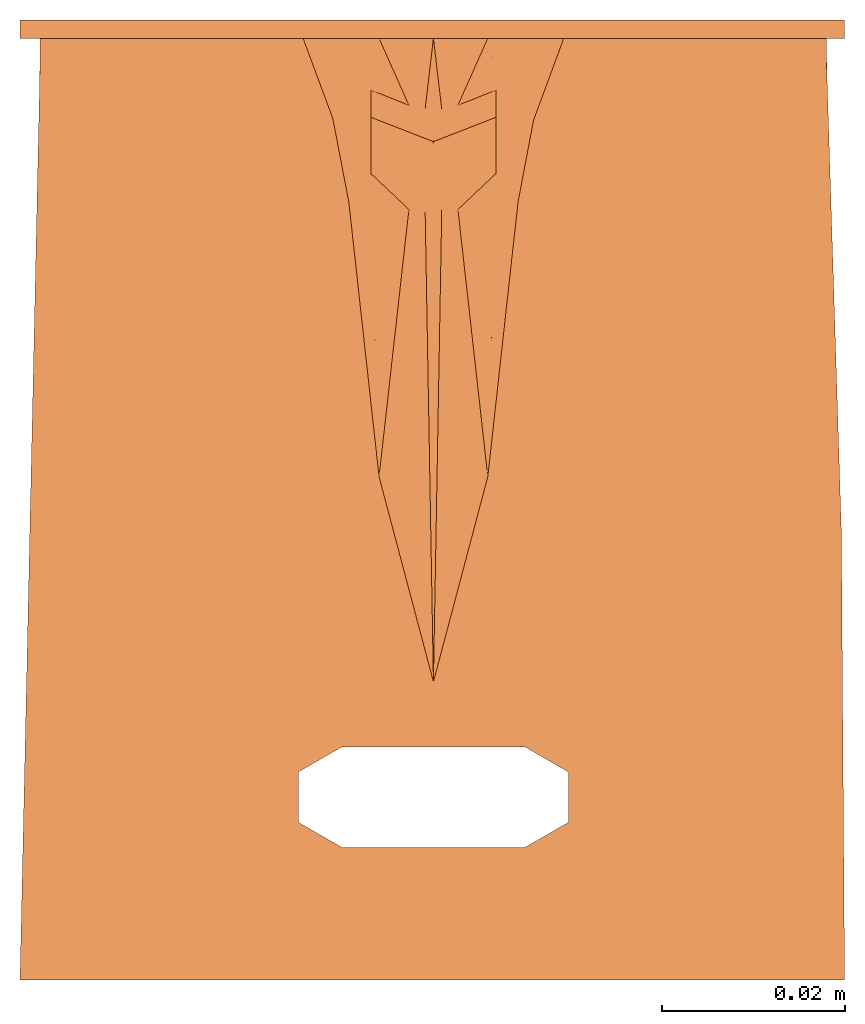
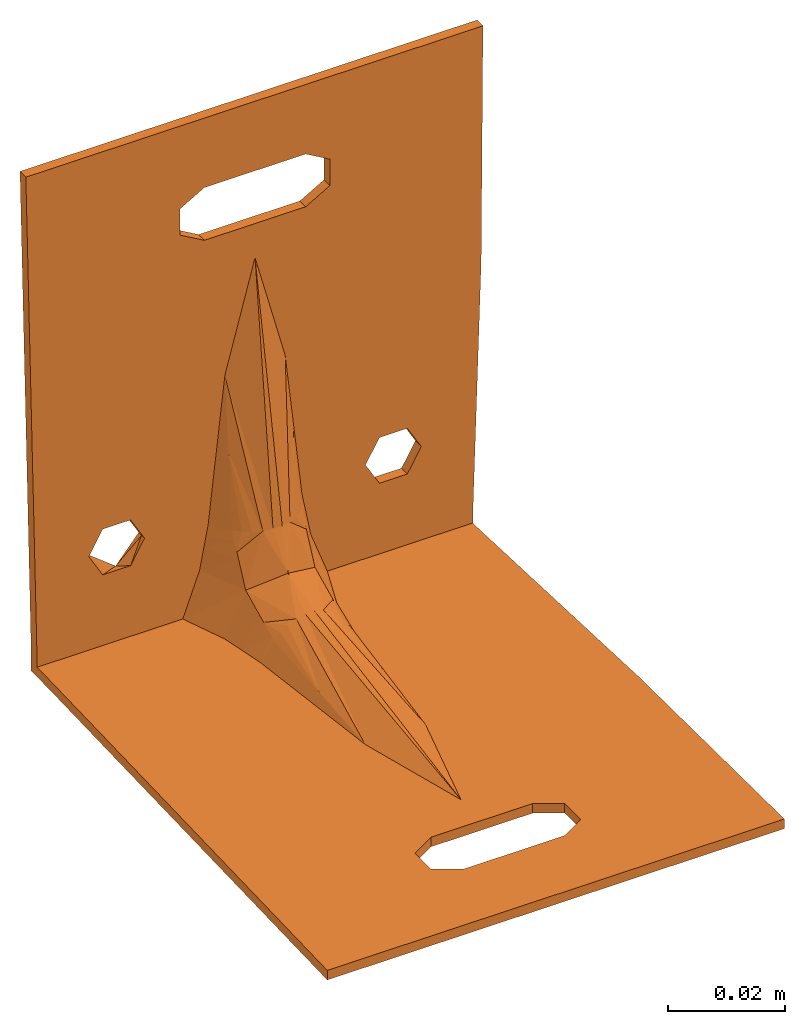
# One storey: 1 proxy.
"""IFC2X3 building model written with IfcOpenShell, lengths in feet."""

import ifcopenshell
import ifcopenshell.guid

model = None  # the IFC model being written
_history = None  # IfcOwnerHistory: only IFC2X3 demands one
_inside = {}  # id of a spatial element -> (the spatial element, [elements in it])
_under = {}  # id of a project, library or spatial element -> (it, [spatial elements below it])
_declared = {}  # id of a project -> (the project, [libraries it declares])
_typed = {}  # id of a type object -> (the type object, [elements of that type])
_made_of = {}  # id of a material, layer set ... -> (it, [elements and type objects made of it])


def new_model(schema):
    """Start an empty IFC model of exactly this schema.

    Asked for "IFC4X3", IfcOpenShell would pick the latest addendum, in which some entities
    have other attributes; the version numbers below select the first issue.
    IFC2X3 requires an IfcOwnerHistory on every rooted entity: one is made here for all.
    """
    global model, _history
    if schema == "IFC4X3":
        model = ifcopenshell.file(schema_version=(4, 3, 0, 0))
    else:
        model = ifcopenshell.file(schema=schema)
    _inside.clear()
    _under.clear()
    _declared.clear()
    _typed.clear()
    _made_of.clear()
    _history = None
    if model.schema == "IFC2X3":
        org = make("IfcOrganization", Name="unknown")
        user = make(
            "IfcPersonAndOrganization",
            ThePerson=make("IfcPerson", FamilyName="unknown"),
            TheOrganization=org,
        )
        app = make(
            "IfcApplication",
            ApplicationDeveloper=org,
            Version="unknown",
            ApplicationFullName="unknown",
            ApplicationIdentifier="unknown",
        )
        _history = make(
            "IfcOwnerHistory",
            OwningUser=user,
            OwningApplication=app,
            ChangeAction="ADDED",
            CreationDate=0,
        )
    return model


def make(cls, **values):
    """One entity of the class cls with the attributes given. An attribute that is None is left unset."""
    return model.create_entity(
        cls, **{name: value for name, value in values.items() if value is not None}
    )


def entity(cls, *values):
    """Any entity or typed value of the class cls, its attributes in the order of the schema. None: left unset."""
    e = model.create_entity(cls)
    for i, value in enumerate(values):
        if value is not None:
            e[i] = value
    return e


def rooted(cls, **values):
    """An entity with a GlobalId (a new one), such as an element, a storey or a relation."""
    return make(cls, GlobalId=ifcopenshell.guid.new(), OwnerHistory=_history, **values)


def si_unit(unit_type, name, prefix=None):
    """IfcSIUnit, for example si_unit("LENGTHUNIT", "METRE", prefix="MILLI")."""
    return make("IfcSIUnit", UnitType=unit_type, Prefix=prefix, Name=name)


def converted_unit(unit_type, name, factor, base, dimensions=None, offset=None):
    """IfcConversionBasedUnit, such as the inch: factor (a typed value) times the base unit."""
    return make(
        "IfcConversionBasedUnit"
        if offset is None
        else "IfcConversionBasedUnitWithOffset",
        ConversionOffset=offset,
        Dimensions=None
        if dimensions is None
        else entity("IfcDimensionalExponents", *dimensions),
        UnitType=unit_type,
        Name=name,
        ConversionFactor=make(
            "IfcMeasureWithUnit", ValueComponent=factor, UnitComponent=base
        ),
    )


def derived_unit(unit_type, elements):
    """IfcDerivedUnit: a product of units, each with its exponent."""
    return make(
        "IfcDerivedUnit",
        Elements=[
            make("IfcDerivedUnitElement", Unit=unit, Exponent=power)
            for unit, power in elements
        ],
        UnitType=unit_type,
    )


def assignment(units):
    """IfcUnitAssignment: the units of a project."""
    return None if units is None else make("IfcUnitAssignment", Units=units)


def point(xyz):
    """IfcCartesianPoint."""
    return None if xyz is None else make("IfcCartesianPoint", Coordinates=xyz)


def direction(xyz):
    """IfcDirection."""
    return None if xyz is None else make("IfcDirection", DirectionRatios=xyz)


def frame(location, z_axis=None, x_axis=None):
    """IfcAxis2Placement3D, a coordinate frame: its origin and axes. An axis left out is left unset."""
    return make(
        "IfcAxis2Placement3D",
        Location=point(location),
        Axis=direction(z_axis),
        RefDirection=direction(x_axis),
    )


def origin():
    """The frame at (0, 0, 0) with its axes left unset."""
    return frame((0.0, 0.0, 0.0))


def place(relative_to, where):
    """IfcLocalPlacement: puts the frame where relative to a parent placement (None: the world)."""
    return make(
        "IfcLocalPlacement", PlacementRelTo=relative_to, RelativePlacement=where
    )


def context(
    kind, dimensions, precision=None, world=None, true_north=None, identifier=None
):
    """IfcGeometricRepresentationContext, for example the 3D "Model" context."""
    return make(
        "IfcGeometricRepresentationContext",
        ContextIdentifier=identifier,
        ContextType=kind,
        CoordinateSpaceDimension=dimensions,
        Precision=precision,
        WorldCoordinateSystem=world,
        TrueNorth=true_north,
    )


def subcontext(parent, identifier, kind, view, scale=None):
    """IfcGeometricRepresentationSubContext, for example "Body" below "Model"."""
    return make(
        "IfcGeometricRepresentationSubContext",
        ContextIdentifier=identifier,
        ContextType=kind,
        ParentContext=parent,
        TargetScale=scale,
        TargetView=view,
    )


def project(units=None, contexts=None):
    """IfcProject with its units and contexts."""
    return rooted(
        "IfcProject",
        Name="project",
        RepresentationContexts=contexts,
        UnitsInContext=assignment(units),
    )


def spatial(cls, under=None, at=None, **own):
    """A site, building, storey or space (cls), placed at a placement, below another one or the project."""
    s = rooted(cls, ObjectPlacement=at, **own)
    if under is not None:
        _under.setdefault(under.id(), (under, []))[1].append(s)
    return s


def faces_of(points, faces, orient=None, outer=None):
    """IfcFace entities. A face is a list of loops; a loop is a list of indices into points, from 0.

    orient and outer hold one flag for each loop. By default every Orientation is true, the
    first loop of a face is its IfcFaceOuterBound and the others are IfcFaceBound.
    """
    made = []
    for i, loops in enumerate(faces):
        bounds = []
        for j, loop in enumerate(loops):
            is_outer = j == 0 if outer is None else outer[i][j]
            bounds.append(
                make(
                    "IfcFaceOuterBound" if is_outer else "IfcFaceBound",
                    Bound=make("IfcPolyLoop", Polygon=[points[k] for k in loop]),
                    Orientation=True if orient is None else orient[i][j],
                )
            )
        made.append(make("IfcFace", Bounds=bounds))
    return made


def faceted_brep(points, faces, orient=None, outer=None, voids=None):
    """IfcFacetedBrep: a solid bounded by flat faces; with voids (closed shells), ...WithVoids."""
    shared = [point(p) for p in points]
    hull = make("IfcClosedShell", CfsFaces=faces_of(shared, faces, orient, outer))
    if voids is None:
        return make("IfcFacetedBrep", Outer=hull)
    return make(
        "IfcFacetedBrepWithVoids",
        Outer=hull,
        Voids=[
            make(cls, CfsFaces=faces_of(shared, fs, o, b)) for cls, fs, o, b in voids
        ],
    )


def shape(context_of_items, identifier, shape_type, items):
    """IfcShapeRepresentation: the items that make up one representation, for example the "Body"."""
    return make(
        "IfcShapeRepresentation",
        ContextOfItems=context_of_items,
        RepresentationIdentifier=identifier,
        RepresentationType=shape_type,
        Items=items,
    )


def source(mapping_origin, context_of_items, identifier, shape_type, items):
    """IfcRepresentationMap: a shape defined once, which mapped items show again and again."""
    return make(
        "IfcRepresentationMap",
        MappingOrigin=mapping_origin,
        MappedRepresentation=shape(context_of_items, identifier, shape_type, items),
    )


def transform(
    local_origin,
    x_axis=None,
    y_axis=None,
    z_axis=None,
    scale=None,
    scale2=None,
    scale3=None,
    uniform=True,
):
    """IfcCartesianTransformationOperator3D, or its non-uniform kind. x_axis, y_axis, z_axis: its Axis1, 2, 3."""
    if uniform:
        return make(
            "IfcCartesianTransformationOperator3D",
            Axis1=direction(x_axis),
            Axis2=direction(y_axis),
            LocalOrigin=point(local_origin),
            Scale=scale,
            Axis3=direction(z_axis),
        )
    return make(
        "IfcCartesianTransformationOperator3DnonUniform",
        Axis1=direction(x_axis),
        Axis2=direction(y_axis),
        LocalOrigin=point(local_origin),
        Scale=scale,
        Axis3=direction(z_axis),
        Scale2=scale2,
        Scale3=scale3,
    )


def mapped(mapping_source, mapping_target):
    """IfcMappedItem: shows the shape of a source again, moved by a transform."""
    return make(
        "IfcMappedItem", MappingSource=mapping_source, MappingTarget=mapping_target
    )


def made_of(thing, what):
    """Note that an element or type object is made of a material, layer set ...; save() writes the relation."""
    if what is not None:
        _made_of.setdefault(what.id(), (what, []))[1].append(thing)
    return thing


def element(
    cls,
    number,
    at=None,
    inside=None,
    cuts=None,
    type_object=None,
    material=None,
    context=None,
    identifier="Body",
    shape_type=None,
    held_by="IfcProductDefinitionShape",
    body=None,
    shapes=None,
    **own,
):
    """One element of the class cls, such as IfcWall. Its Tag is "e" and its number.

    at: its placement. inside: the storey or other place that contains it. cuts: it is an
    opening in that element (IfcRelVoidsElement). A single representation is given by context,
    identifier, shape_type and body (its items); several are given by shapes. held_by: the class
    of the entity that holds the representations. save() writes the other relations.
    """
    e = rooted(cls, Tag="e%d" % number, ObjectPlacement=at, **own)
    if body is not None:
        shapes = [shape(context, identifier, shape_type, body)]
    if shapes is not None:
        e.Representation = make(held_by, Representations=shapes)
    if inside is not None:
        _inside.setdefault(inside.id(), (inside, []))[1].append(e)
    if cuts is not None:
        rooted(
            "IfcRelVoidsElement", RelatingBuildingElement=cuts, RelatedOpeningElement=e
        )
    if type_object is not None:
        _typed.setdefault(type_object.id(), (type_object, []))[1].append(e)
    return made_of(e, material)


def aggregate(whole, parts):
    """IfcRelAggregates: a whole, such as a stair, and the parts it consists of."""
    return rooted("IfcRelAggregates", RelatingObject=whole, RelatedObjects=parts)


def save(model, path):
    """Write the relations noted so far, then the file.

    IfcRelAggregates (storeys below a building ...), IfcRelContainedInSpatialStructure (elements
    in a storey), IfcRelDefinesByType, IfcRelAssociatesMaterial and IfcRelDeclares: one each for
    every whole, place, type object, material and project.
    """
    for whole, parts in _under.values():
        aggregate(whole, parts)
    for where, things in _inside.values():
        rooted(
            "IfcRelContainedInSpatialStructure",
            RelatedElements=things,
            RelatingStructure=where,
        )
    for kind, things in _typed.values():
        rooted("IfcRelDefinesByType", RelatedObjects=things, RelatingType=kind)
    for what, things in _made_of.values():
        rooted("IfcRelAssociatesMaterial", RelatedObjects=things, RelatingMaterial=what)
    for by, libraries in _declared.values():
        rooted("IfcRelDeclares", RelatingContext=by, RelatedDefinitions=libraries)
    model.write(path)


model = new_model("IFC2X3")

# Units and contexts
model_context = context("Model", 3, precision=1e-09, world=origin(), true_north=direction((2.0, 6.12303176911189e-17, 1.0)))
context_of_model = context(None, 3, precision=1e-09, world=origin(), true_north=direction((2.0, 6.12303176911189e-17, 1.0)))
body_context = subcontext(model_context, "Body", "Model", "MODEL_VIEW")
ifc_project = project(units=[converted_unit("LENGTHUNIT", "FOOT", entity("IfcRatioMeasure", 0.3048), si_unit("LENGTHUNIT", "METRE"), dimensions=[1, 0, 0, 0, 0, 0, 0]), converted_unit("AREAUNIT", "SQUARE FOOT", entity("IfcRatioMeasure", 0.09290304), si_unit("AREAUNIT", "SQUARE_METRE"), dimensions=[2, 0, 0, 0, 0, 0, 0]), converted_unit("VOLUMEUNIT", "CUBIC FOOT", entity("IfcRatioMeasure", 0.028316846592), si_unit("VOLUMEUNIT", "CUBIC_METRE"), dimensions=[3, 0, 0, 0, 0, 0, 0]), converted_unit("PLANEANGLEUNIT", "DEGREE", entity("IfcRatioMeasure", 0.0174532925199433), si_unit("PLANEANGLEUNIT", "RADIAN"), dimensions=[0, 0, 0, 0, 0, 0, 0]), si_unit("MASSUNIT", "GRAM", prefix="KILO"), si_unit("TIMEUNIT", "SECOND"), si_unit("THERMODYNAMICTEMPERATUREUNIT", "KELVIN"), derived_unit("THERMALTRANSMITTANCEUNIT", [(si_unit("MASSUNIT", "GRAM", prefix="KILO"), 1), (si_unit("THERMODYNAMICTEMPERATUREUNIT", "KELVIN"), -1), (si_unit("TIMEUNIT", "SECOND"), -3)]), derived_unit("VOLUMETRICFLOWRATEUNIT", [(si_unit("LENGTHUNIT", "METRE"), 3), (si_unit("TIMEUNIT", "SECOND"), -1)]), si_unit("POWERUNIT", "WATT")], contexts=[model_context, context_of_model])

# Site, building, storey
site_placement = place(None, origin())
site = spatial("IfcSite", under=ifc_project, at=site_placement, CompositionType="ELEMENT")
building_placement = place(site_placement, origin())
building = spatial("IfcBuilding", under=site, at=building_placement, CompositionType="ELEMENT")
storey_placement = place(building_placement, origin())
storey = spatial("IfcBuildingStorey", under=building, at=storey_placement, Name="Level 1", CompositionType="ELEMENT", Elevation=0.0)

# Proxy
shared_shape = source(origin(), body_context, "Body", "Brep", [
    faceted_brep([(0.10761154855643, -0.00328083989501315, 0.0705380577427821), (0.10761154855643, -0.0065616797900262, 0.0705380577427821), (0.0985892388451444, -0.0065616797900262, 0.0861651565643517), (0.0985892388451444, 0.0, 0.0861651565643517), (0.10761154855643, 0.0, 0.0705380577427821), (0.0805446194225722, -0.0065616797900262, 0.0861651565643517), (0.0805446194225722, 0.0, 0.0861651565643517), (-0.0805446194225722, -0.0065616797900262, 0.0861651565643517), (-0.0985892388451444, -0.0065616797900262, 0.0861651565643517), (-0.0985892388451444, 0.0, 0.0861651565643517), (-0.0805446194225722, 0.0, 0.0861651565643517), (0.0715223097112861, -0.00328083989501315, 0.0705380577427821), (0.0715223097112861, 0.0, 0.0705380577427821), (0.0715223097112861, -0.00656167979002631, 0.0705380577427821), (-0.0715223097112861, -0.00328083989501315, 0.0705380577427821), (-0.0715223097112861, -0.0065616797900262, 0.0705380577427821), (-0.0715223097112861, 0.0, 0.0705380577427821), (-0.10761154855643, -0.00328083989501315, 0.0705380577427821), (-0.10761154855643, 0.0, 0.0705380577427821), (-0.10761154855643, -0.00656167979002631, 0.0705380577427821), (0.145129316038234, -0.143508295989698, 0.0), (0.143861073393889, -0.103327490414825, 0.0), (0.142592830749543, -0.0631466848399522, 0.0), (0.141324588105198, -0.0229658792650814, 0.0), (0.141324588105198, -0.0229658792650784, 0.00656167979002622), (0.142591388769956, -0.0631009996536641, 0.00656167979002622), (0.143858189434713, -0.10323612004225, 0.00656167979002623), (0.145127874058646, -0.143462610803407, 0.00656167979002623), (0.146397558682579, -0.183689101564567, 0.00656167979002622), (0.146397558682579, -0.183689101564567, 0.0), (0.14668724648245, -0.223888873417518, 0.00656167979002622), (0.14697693428232, -0.264088645270464, 0.00656167979002622), (0.147266622082191, -0.304288417123415, 0.00656167979002621), (0.147556309882062, -0.344488188976366, 0.00656167979002621), (0.147556309882062, -0.344488188976366, 0.0), (0.14726695145441, -0.304334123874172, 0.0), (0.14697693428232, -0.264088645270464, 0.0), (0.14668724648245, -0.223888873417516, 0.0), (-0.0328083989501312, -0.296916010498688, 0.00656167979002622), (-0.0484354977717008, -0.287893700787402, 0.00656167979002622), (-0.148355205181298, -0.344488188976378, 0.00656167979002622), (0.0328083989501312, -0.296916010498688, 0.00656167979002622), (-0.0484354977717008, -0.269849081364829, 0.00656167979002622), (-0.141324588105199, -0.0229658792650918, 0.00656167979002622), (-0.019510284141231, -0.163898240643676, 0.00656167979002622), (-0.0328083989501312, -0.260826771653543, 0.00656167979002622), (0.0, -0.237475976437017, 0.00656167979002622), (0.0328083989501313, -0.260826771653543, 0.00656167979002622), (0.019510284141231, -0.163898240643676, 0.00656167979002622), (0.0484354977717008, -0.269849081364829, 0.00656167979002622), (0.0484354977717009, -0.287893700787401, 0.00656167979002622), (0.0303777390761584, -0.0652007556682695, 0.00656167979002622), (0.0331512166187571, -0.0505732413753644, 0.00656167979002622), (0.0359246941613567, -0.0359457270824463, 0.00656167979002622), (0.0467750811003519, -0.0065616797900262, 0.00656167979002622), (0.141220457490618, -0.0198761513358741, 0.00656167979002623), (0.141048720634281, -0.0147804341576518, 0.00656167979002622), (0.140993278080835, -0.0065616797900262, 0.00656167979002622), (-0.0303777390761579, -0.0652007556682768, 0.00656167979002622), (-0.0332587031324537, -0.0502118414319206, 0.00656167979002621), (-0.0361396671887491, -0.0352229271955717, 0.00656167979002622), (-0.0467750811003518, -0.0065616797900262, 0.00656167979002622), (-0.141262826481964, -0.0192658707050665, 0.00656167979002622), (-0.141187923489634, -0.0147785904446627, 0.00656167979002622), (-0.141158952890293, -0.00656167978998973, 0.00656167979002622), (-0.148355205181298, -0.344488188976378, 0.0), (-0.141324588105198, -0.0229658792650918, 0.0), (-0.141324588105206, 0.0, 0.0229658792668358), (-0.141324588105195, -0.00656167979002624, 0.0229658792663363), (-0.148355205181285, -0.00656167979002624, 0.344488188976378), (-0.148355205181285, 0.0, 0.344488188976378), (-0.14118664388565, -0.00656167979002624, 0.0147787344233476), (-0.0985892388451444, -0.00656167979002624, 0.0549109589212125), (-0.141262259050653, -0.00656167979002624, 0.0192665796569134), (-0.0805446194225722, -0.00656167979002624, 0.0549109589212125), (-0.0359246941613566, -0.00656167979002624, 0.0359457270824464), (-0.033151216618757, -0.00656167979002624, 0.0505732413753645), (-0.0317644778474572, -0.00656167979002624, 0.0578869985218235), (-0.0303777390761583, -0.00656167979002624, 0.0652007556682696), (-0.019510284141231, -0.00656167979002624, 0.163898240643676), (-0.0484354977717008, -0.00656167979002624, 0.269849081364829), (-0.0328083989501312, -0.00656167979002624, 0.260826771653543), (0.0, -0.00656167979002624, 0.237475976437018), (0.0328083989501313, -0.00656167979002624, 0.260826771653543), (0.019510284141231, -0.00656167979002624, 0.163898240643676), (0.0484354977717008, -0.00656167979002624, 0.269849081364829), (0.146397558682564, -0.00656167979002624, 0.183689101565208), (0.0303777390761579, -0.00656167979002624, 0.065200755668277), (0.0318182211043061, -0.00656167979002624, 0.0577062985500951), (0.0332587031324537, -0.00656167979002624, 0.0502118414319207), (0.0361396671887491, -0.00656167979002624, 0.0352229271955719), (0.0805446194225722, -0.00656167979002624, 0.0549109589212125), (0.0985892388451444, -0.00656167979002624, 0.0549109589212125), (0.141051210941871, -0.00656167979002624, 0.0147802530666699), (0.141221378725023, -0.00656167979002625, 0.0198755208906127), (0.14132458810519, -0.00656167979002624, 0.022965879266342), (0.142592830749534, -0.00656167979002624, 0.0631466848410573), (0.143861073393877, -0.00656167979002624, 0.103327490415771), (0.14512931603822, -0.00656167979002624, 0.143508295990489), (0.146687575854658, -0.00656167979002624, 0.223934580168606), (0.146977593026753, -0.00656167979002624, 0.264180058772005), (0.147266951454412, -0.00656167979002624, 0.304334123874193), (0.14755630988207, -0.00656167979002624, 0.344488188976378), (0.0484354977717009, -0.00656167979002624, 0.287893700787402), (0.0328083989501313, -0.00656167979002624, 0.296916010498688), (-0.0328083989501312, -0.00656167979002624, 0.296916010498688), (-0.0484354977717008, -0.00656167979002624, 0.287893700787402), (0.14755630988207, 0.0, 0.344488188976378), (0.146687246482442, 0.0, 0.223888873418078), (0.146976934282318, 0.0, 0.264088645270846), (0.147266622082195, 0.0, 0.304288417123613), (0.146397558682565, 0.0, 0.18368910156531), (0.141324588105199, 0.0, 0.0229658792665588), (0.142591388769959, 0.0, 0.0631009996551502), (0.143861073393882, 0.0, 0.103327490415932), (0.145129316038224, 0.0, 0.143508295990621), (0.141187915217625, 0.0, 0.0172371656461655), (0.141051242330051, 0.0, 0.0115084520254971), (0.141256251661412, 0.0, 0.0201015224564997), (0.140990871628093, -5.04719331581756e-06, 8.88518819815338e-06), (0.141117694242753, -0.0143716947195998, 0.0), (0.141048729621938, -0.0115069665377691, 0.0), (0.141186658863568, -0.0172364229014305, 0.0), (0.022437238655941, -0.0272367615064985, 0.0508074124253325), (0.022437238655941, -0.063707309993693, 0.021003792355327), (0.022437238655941, -0.0224495021053245, 0.0607152355527274), (0.022437238655941, -0.0349154404103839, 0.034915440410384), (0.0224372386559411, -0.0251611067906145, 0.0551032355832499), (0.022437238655941, -0.0508074124253324, 0.0272367615064985), (0.0224372386559411, -0.0551032354392261, 0.0251611068602039), (0.022437238655941, -0.0587533984328066, 0.0233974220545557), (0.022437238655941, -0.019558082602613, 0.0666993844402809), (0.022437238655941, -0.0666993844402809, 0.019558082602613), (-0.0328083989501312, -0.296916010498688, 0.0), (-0.0484354977717008, -0.287893700787402, 0.0), (-0.0484354977717008, -0.269849081364829, 0.0), (-0.0328083989501312, -0.260826771653543, 0.0), (-0.141290421357246, -0.0201002354215059, 0.0), (-0.141256254609294, -0.01723459157792, 0.0), (-0.14118792111339, -0.0115033038907481, 0.0), (0.0328083989501312, -0.260826771653543, 0.0), (0.0484354977717008, -0.269849081364829, 0.0), (0.0328083989501314, -0.296916010498688, 0.0), (0.0484354977717009, -0.287893700787401, 0.0), (-0.141158952890293, 0.0, 0.0), (-0.141221138464453, 0.0, 0.014370725453587), (-0.141186655250871, 0.0, 0.0115056741825048), (-0.141255621678035, 0.0, 0.0172357767246693), (-0.022437238655941, -0.0272367615064985, 0.0508074124253325), (-0.022437238655941, -0.063707309993693, 0.021003792355327), (-0.022437238655941, -0.0508074124253324, 0.0272367615064985), (-0.022437238655941, -0.034915440410384, 0.034915440410384), (-0.0224372386559411, -0.0251611067949283, 0.0551032355743221), (-0.022437238655941, -0.0224495021053245, 0.0607152355527274), (-0.022437238655941, -0.0587533984328066, 0.0233974220545558), (-0.022437238655941, -0.0551032354155741, 0.0251611068716321), (-0.022437238655941, -0.019558082602613, 0.0666993844402809), (-0.022437238655941, -0.0666993844402808, 0.019558082602613), (-0.0864741967335332, 0.0, 0.0527604511433141), (0.0805446194225722, 0.0, 0.0549109589212125), (-0.106551399436515, 0.0, 0.0644441215235864), (-0.0328083989501312, 0.0, 0.260826771653543), (-0.0484354977717008, 0.0, 0.269849081364829), (-0.107344535733326, 0.0, 0.0674453253424571), (-0.0484354977717008, 0.0, 0.287893700787402), (-0.0328083989501312, 0.0, 0.296916010498688), (0.0328083989501313, 0.0, 0.296916010498688), (0.0484354977717009, 0.0, 0.287893700787402), (0.0484354977717008, 0.0, 0.269849081364829), (0.0328083989501312, 0.0, 0.260826771653543), (0.0985892388451444, 0.0, 0.0549109589212125), (-0.020973761398586, -0.0130598811963196, 0.115298812541979), (0.020973761398586, -0.0130598811963196, 0.115298812541978), (-0.00879683451054365, -0.0305952018249576, 0.0679720861766379), (-0.00298388211330531, -0.0319342370328794, 0.0681264917239658), (-0.0187817131373967, -0.0242427025792724, 0.0672395728587906), (-0.0141550972514937, -0.0279864093634705, 0.0676712635952171), (0.00879628324475274, -0.0305953966314687, 0.0679721086400266), (0.0141546045262694, -0.0279867228334482, 0.0676712997418429), (0.00298330080070321, -0.0319343031067897, 0.0681264993430333), (0.0187813044206571, -0.0242431185101204, 0.0672396208203117), (0.020973761398586, -0.115298812541978, 0.0130598811963196), (0.00879628324475268, -0.067972108640026, 0.0305953966314687), (0.00298330080070314, -0.0681264993430322, 0.0319343031067898), (0.018781304420657, -0.0672396208203118, 0.0242431185101204), (0.0141546045262694, -0.0676712997418427, 0.0279867228334482), (-0.0209737613985862, -0.115298812541977, 0.0130598811963139), (-0.00879683451054371, -0.0679720861766362, 0.0305952018249578), (-0.0141550972514938, -0.0676712635952155, 0.0279864093634707), (-0.00298388211330538, -0.0681264917239645, 0.0319342370328796), (-0.0187817131373968, -0.0672395728587887, 0.0242427025792725), (0.0, -0.0436523227370484, 0.0440389992950742)], [[[0, 1, 2, 3, 4]], [[2, 5, 6, 3]], [[7, 8, 9, 10]], [[11, 12, 6, 5, 13]], [[14, 15, 7, 10, 16]], [[17, 18, 9, 8, 19]], [[20, 21, 22, 23, 24, 25, 26, 27, 28, 29]], [[29, 28, 30, 31, 32, 33, 34, 35, 36, 37]], [[38, 39, 40]], [[33, 38, 40]], [[38, 33, 41]], [[42, 40, 39]], [[43, 40, 42]], [[42, 44, 43]], [[45, 44, 42]], [[44, 45, 46]], [[47, 46, 45]], [[46, 47, 48]], [[47, 49, 48]], [[49, 50, 33]], [[49, 33, 32]], [[49, 28, 48]], [[49, 32, 31]], [[49, 31, 30]], [[49, 30, 28]], [[48, 28, 51]], [[51, 28, 27]], [[51, 27, 26]], [[51, 26, 25]], [[51, 25, 24]], [[24, 52, 51]], [[24, 53, 52]], [[53, 24, 54]], [[54, 24, 55]], [[54, 55, 56]], [[56, 57, 54]], [[50, 41, 33]], [[43, 44, 58]], [[43, 58, 59]], [[43, 59, 60]], [[61, 43, 60]], [[61, 62, 43]], [[61, 63, 62]], [[61, 64, 63]], [[34, 33, 40, 65]], [[65, 40, 43, 66]], [[67, 68, 69, 70]], [[71, 64, 72]], [[72, 73, 71]], [[64, 61, 72]], [[72, 61, 74]], [[74, 61, 75]], [[75, 15, 74]], [[15, 75, 76]], [[15, 76, 77]], [[15, 77, 78]], [[15, 78, 7]], [[79, 7, 78]], [[79, 8, 7]], [[79, 80, 8]], [[79, 81, 80]], [[82, 81, 79]], [[81, 82, 83]], [[83, 82, 84]], [[84, 85, 83]], [[85, 84, 86]], [[84, 5, 86]], [[84, 87, 5]], [[87, 13, 5]], [[13, 87, 88]], [[13, 88, 89]], [[13, 89, 90]], [[90, 91, 13]], [[91, 90, 54]], [[54, 92, 91]], [[57, 92, 54]], [[57, 93, 92]], [[92, 93, 94]], [[92, 94, 95]], [[95, 1, 92]], [[1, 95, 96]], [[1, 96, 97]], [[1, 97, 98]], [[1, 98, 86]], [[86, 5, 2]], [[1, 86, 2]], [[85, 86, 99]], [[85, 99, 100]], [[85, 100, 101]], [[85, 101, 102]], [[102, 103, 85]], [[104, 103, 102]], [[102, 105, 104]], [[105, 102, 69]], [[105, 69, 106]], [[80, 106, 69]], [[8, 80, 69]], [[69, 19, 8]], [[19, 69, 68]], [[72, 68, 73]], [[68, 72, 19]], [[70, 69, 102, 107]], [[108, 109, 110, 107, 102, 101, 100, 99, 86, 111]], [[111, 86, 98, 97, 96, 95, 112, 113, 114, 115]], [[116, 93, 117]], [[93, 116, 94]], [[94, 116, 118]], [[118, 112, 95]], [[57, 119, 117]], [[55, 120, 56]], [[117, 93, 57]], [[56, 120, 121]], [[55, 24, 23]], [[56, 121, 57]], [[55, 23, 122, 120]], [[57, 121, 119]], [[95, 94, 118]], [[89, 123, 90]], [[52, 124, 51]], [[88, 87, 125, 89]], [[54, 90, 126]], [[123, 126, 90]], [[89, 125, 127, 123]], [[52, 128, 129, 130, 124]], [[87, 131, 125]], [[53, 126, 128]], [[51, 124, 132]], [[126, 53, 54]], [[52, 53, 128]], [[65, 133, 34]], [[133, 65, 134]], [[135, 134, 65]], [[65, 66, 135]], [[66, 136, 135]], [[23, 136, 66]], [[66, 122, 23]], [[66, 120, 122]], [[66, 121, 120]], [[121, 66, 137]], [[121, 137, 138]], [[121, 138, 139]], [[23, 140, 136]], [[140, 23, 22]], [[140, 22, 21]], [[140, 21, 20]], [[140, 20, 29]], [[140, 29, 141]], [[141, 29, 37]], [[141, 37, 36]], [[141, 36, 35]], [[141, 35, 34]], [[142, 34, 133]], [[34, 142, 143]], [[143, 141, 34]], [[119, 139, 144]], [[139, 119, 121]], [[138, 63, 139]], [[63, 138, 62]], [[62, 138, 137]], [[137, 66, 43]], [[64, 144, 139]], [[73, 145, 71]], [[139, 63, 64]], [[71, 145, 146]], [[73, 68, 67]], [[71, 146, 64]], [[73, 67, 147, 145]], [[64, 146, 144]], [[43, 62, 137]], [[75, 148, 76]], [[58, 149, 59]], [[150, 151, 60]], [[151, 75, 61]], [[75, 151, 148]], [[76, 148, 152, 153]], [[59, 149, 154, 155, 150]], [[77, 153, 156]], [[77, 156, 78]], [[157, 149, 58]], [[61, 60, 151]], [[150, 60, 59]], [[77, 76, 153]], [[158, 146, 145]], [[144, 146, 158]], [[144, 158, 159]], [[158, 16, 159]], [[158, 145, 147]], [[158, 147, 67]], [[160, 158, 67]], [[16, 12, 159]], [[12, 16, 10]], [[10, 6, 12]], [[10, 161, 6]], [[10, 162, 161]], [[162, 10, 9]], [[70, 162, 9]], [[9, 18, 70]], [[18, 163, 67]], [[67, 70, 18]], [[163, 160, 67]], [[70, 164, 162]], [[164, 70, 165]], [[70, 107, 165]], [[166, 165, 107]], [[107, 167, 166]], [[167, 107, 168]], [[168, 107, 110]], [[168, 110, 109]], [[168, 109, 108]], [[168, 108, 111]], [[6, 169, 111]], [[111, 3, 6]], [[3, 111, 4]], [[4, 111, 115]], [[169, 168, 111]], [[4, 115, 114]], [[4, 114, 113]], [[4, 113, 112]], [[170, 4, 112]], [[170, 112, 118]], [[170, 118, 116]], [[170, 116, 117]], [[169, 6, 161]], [[119, 170, 117]], [[170, 119, 159]], [[159, 119, 144]], [[78, 156, 171, 79]], [[172, 131, 87, 84]], [[79, 171, 173]], [[82, 79, 174]], [[174, 79, 173]], [[171, 156, 175]], [[171, 176, 173]], [[176, 171, 175]], [[172, 177, 178]], [[82, 179, 84]], [[172, 84, 177]], [[180, 172, 178]], [[84, 179, 177]], [[172, 180, 131]], [[174, 179, 82]], [[51, 132, 181, 48]], [[48, 181, 182]], [[46, 48, 183]], [[183, 48, 182]], [[181, 132, 184]], [[181, 185, 182]], [[185, 181, 184]], [[186, 187, 188]], [[46, 189, 44]], [[186, 44, 187]], [[190, 186, 188]], [[44, 189, 187]], [[186, 190, 157]], [[183, 189, 46]], [[186, 157, 58, 44]], [[38, 41, 142, 133]], [[141, 49, 47, 140]], [[141, 143, 50, 49]], [[167, 168, 85, 103]], [[142, 41, 50, 143]], [[140, 47, 45, 136]], [[134, 39, 38, 133]], [[134, 135, 42, 39]], [[162, 164, 106, 80]], [[136, 45, 42, 135]], [[166, 104, 105, 165]], [[167, 103, 104, 166]], [[168, 169, 83, 85]], [[162, 80, 81, 161]], [[164, 165, 105, 106]], [[161, 81, 83, 169]], [[173, 152, 148, 151]], [[152, 173, 176]], [[176, 175, 152]], [[151, 191, 173]], [[178, 177, 127]], [[180, 127, 125, 131]], [[175, 156, 153, 152]], [[174, 191, 179]], [[173, 191, 174]], [[177, 179, 191]], [[184, 132, 124, 130, 129]], [[177, 126, 123, 127]], [[191, 126, 177]], [[178, 127, 180]], [[191, 189, 183]], [[187, 151, 150, 155]], [[155, 188, 187]], [[187, 189, 191]], [[191, 182, 126]], [[183, 182, 191]], [[188, 155, 190]], [[182, 185, 129]], [[151, 187, 191]], [[182, 129, 128, 126]], [[184, 129, 185]], [[190, 155, 154, 149, 157]], [[17, 163, 18]], [[72, 17, 19]], [[163, 17, 160]], [[160, 17, 158]], [[14, 16, 158]], [[74, 14, 158]], [[158, 72, 74]], [[14, 74, 15]], [[17, 72, 158]], [[11, 13, 91, 159, 12]], [[91, 92, 170, 159]], [[0, 4, 170, 92, 1]]]),
])
proxy_placement = place(storey_placement, origin())
element("IfcBuildingElementProxy", 1, at=proxy_placement, inside=storey, ObjectType="C_10520_3D_Cad_Prod", CompositionType="ELEMENT", context=body_context, shape_type="MappedRepresentation", body=[
    mapped(shared_shape, transform((0.0, 0.0, 0.0), scale=1.0)),
])

save(model, "model.ifc")
